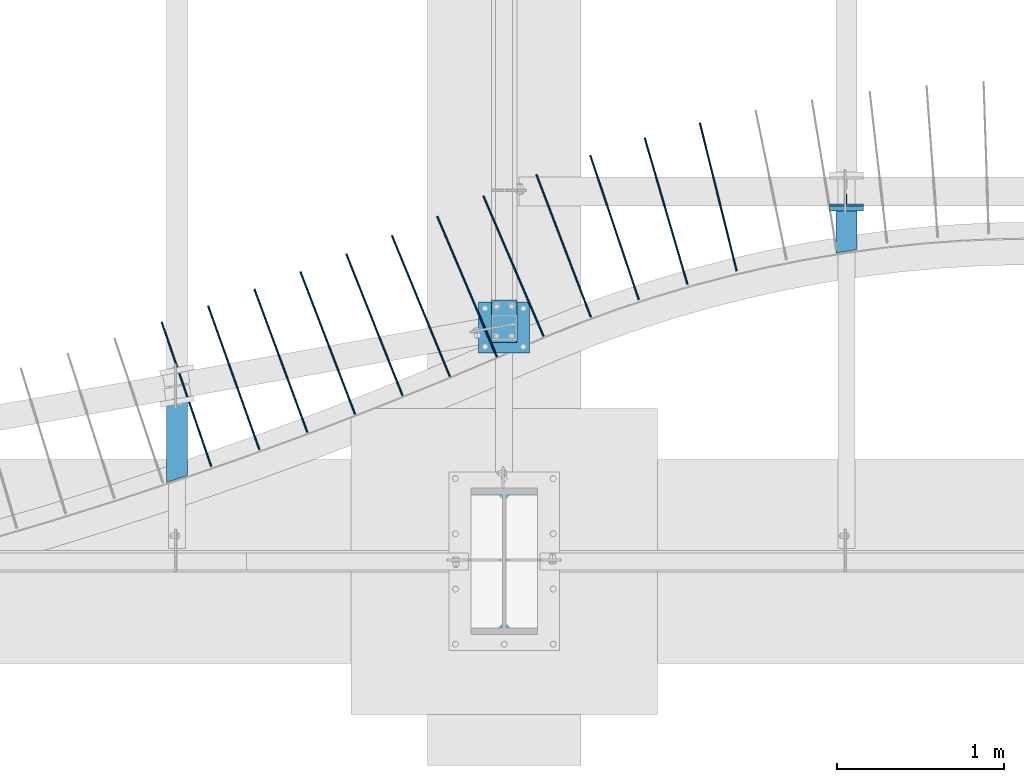
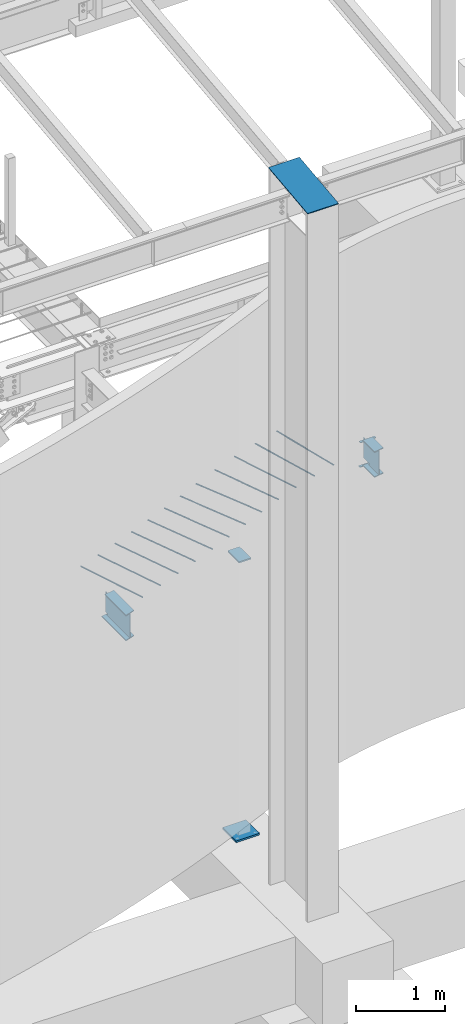
# One storey, part 808 of 1179: 19 beams, 16 elements without a shape of their own.
"""IFC2X3 building model written with IfcOpenShell, lengths in millimetres."""

from ifc_helpers import new_model, si_unit, frame, origin_with_axes, place, context, subcontext, project, spatial, faceted_brep, material, type_object, element, aggregate, save


model = new_model("IFC2X3")

# Units and contexts
model_context = context("Model", 3, precision=1e-05, world=origin_with_axes())
body_context = subcontext(model_context, "Body", "Model", "MODEL_VIEW")
ifc_project = project(units=[si_unit("LENGTHUNIT", "METRE", prefix="MILLI"), si_unit("AREAUNIT", "SQUARE_METRE"), si_unit("VOLUMEUNIT", "CUBIC_METRE"), si_unit("MASSUNIT", "GRAM", prefix="KILO"), si_unit("TIMEUNIT", "SECOND"), si_unit("PLANEANGLEUNIT", "RADIAN"), si_unit("SOLIDANGLEUNIT", "STERADIAN"), si_unit("THERMODYNAMICTEMPERATUREUNIT", "DEGREE_CELSIUS"), si_unit("LUMINOUSINTENSITYUNIT", "LUMEN")], contexts=[model_context])

# Site, building, storey
site_placement = place(None, origin_with_axes())
site = spatial("IfcSite", under=ifc_project, at=site_placement, CompositionType="ELEMENT")
building_placement = place(site_placement, origin_with_axes())
building = spatial("IfcBuilding", under=site, at=building_placement, Name="Undefined", CompositionType="ELEMENT")
storey_placement = place(building_placement, origin_with_axes())
storey = spatial("IfcBuildingStorey", under=building, at=storey_placement, Name="Undefined", CompositionType="ELEMENT", Elevation=0.0)

# Assembly, beams
assembly_1_placement = place(storey_placement, origin_with_axes())
assembly_1 = element("IfcElementAssembly", 1, at=assembly_1_placement, inside=storey, Name="BEAM", AssemblyPlace="NOTDEFINED", PredefinedType="RIGID_FRAME")
ifc_material_1 = material(Name="STEEL/A36")
beam_type_1 = type_object("IfcBeamType", PredefinedType="NOTDEFINED")
beam_1_placement = place(assembly_1_placement, frame((10325.1, 2530.47499999652, 3831.8280002594), z_axis=(-1.0, 0.0, 0.0), x_axis=(0.0, 1.0, 0.0)))
beam_1 = element("IfcBeam", 2, at=beam_1_placement, type_object=beam_type_1, material=ifc_material_1, Name="PLATE", context=body_context, shape_type="Brep", body=[
    faceted_brep([(0.0, 4.76250000000073, -101.6), (0.0, 4.76250000000073, 101.6), (31.75, 4.76249999999982, 101.6), (31.75, 4.76249999999982, -101.6), (0.0, -4.76250000000073, 101.6), (31.75, -4.76249999999982, 101.6), (0.0, -4.76250000000073, -101.6), (31.75, -4.76249999999982, -101.6)], [[[0, 1, 2, 3]], [[1, 4, 5, 2]], [[4, 6, 7, 5]], [[6, 0, 3, 7]], [[5, 7, 3, 2]], [[6, 4, 1, 0]]]),
])
beam_2_placement = place(assembly_1_placement, frame((10325.1, 2541.58712563067, 3490.9125), z_axis=(-1.0, 0.0, 0.0), x_axis=(0.0, 1.0, 0.0)))
beam_2 = element("IfcBeam", 3, at=beam_2_placement, type_object=beam_type_1, material=ifc_material_1, Name="PLATE", context=body_context, shape_type="Brep", body=[
    faceted_brep([(0.0, 4.76250000000073, -101.6), (0.0, 4.76250000000073, 101.6), (31.75, 4.76249999999982, 101.6), (31.75, 4.76249999999982, -101.6), (0.0, -4.76250000000073, 101.6), (31.75, -4.76249999999982, 101.6), (0.0, -4.76250000000073, -101.6), (31.75, -4.76249999999982, -101.6)], [[[0, 1, 2, 3]], [[1, 4, 5, 2]], [[4, 6, 7, 5]], [[6, 0, 3, 7]], [[5, 7, 3, 2]], [[6, 4, 1, 0]]]),
])

# Assembly, beam
assembly_2_placement = place(storey_placement, origin_with_axes())
assembly_2 = element("IfcElementAssembly", 4, at=assembly_2_placement, inside=storey, Name="COLUMN", AssemblyPlace="NOTDEFINED", PredefinedType="RIGID_FRAME")
beam_type_2 = type_object("IfcBeamType", PredefinedType="NOTDEFINED")
beam_3_placement = place(assembly_2_placement, frame((8280.4, 876.834752967023, 9341.1779874812), z_axis=(1.0, 0.0, 0.0), x_axis=(0.0, -0.993676146336441, -0.112284087038017)))
beam_3 = element("IfcBeam", 5, at=beam_3_placement, type_object=beam_type_2, material=ifc_material_1, Name="PLATE", context=body_context, shape_type="Brep", body=[
    faceted_brep([(1.07631237348505, 4.76249999999709, -200.025), (1.07631237348505, 4.76249999999709, 200.025), (882.953172586766, 4.762499999586, 200.025), (882.953172586766, 4.762499999586, -200.025), (2.52225618169177e-09, -4.76249999999709, 200.025), (881.876860215802, -4.76250000041, 200.025), (2.52225618169177e-09, -4.76249999999709, -200.025), (881.876860215802, -4.76250000041, -200.025)], [[[0, 1, 2, 3]], [[1, 4, 5, 2]], [[4, 6, 7, 5]], [[6, 0, 3, 7]], [[5, 7, 3, 2]], [[6, 4, 1, 0]]]),
])
aggregate(assembly_2, [beam_3])

assembly_3_placement = place(storey_placement, origin_with_axes())
assembly_3 = element("IfcElementAssembly", 6, at=assembly_3_placement, inside=storey, Name="#4 DOWEL", AssemblyPlace="NOTDEFINED", PredefinedType="NOTDEFINED")
ifc_material_2 = material(Name="REBAR/A615-40")
beam_type_3 = type_object("IfcBeamType", Name="#4 DOWEL", PredefinedType="NOTDEFINED")
beam_4_placement = place(assembly_3_placement, frame((9669.62575980426, 2171.91771749365, 3943.35000610352), z_axis=(-0.970440166759231, -0.241341837940122, 0.0), x_axis=(-0.241341837940122, 0.970440166759231, 0.0)))
beam_4 = element("IfcBeam", 7, at=beam_4_placement, type_object=beam_type_3, material=ifc_material_2, Name="#4 DOWEL", ObjectType="#4 DOWEL", context=body_context, shape_type="Brep", body=[
    faceted_brep([(0.0, -6.34999999999854, 0.0), (0.0, -4.49012806053361, -4.49012806053452), (914.399999999994, -4.49012806053452, -4.49012806042992), (914.399999999994, -6.34999999999991, 1.0550138540566e-10), (0.0, 0.0, -6.34999999999991), (914.399999999994, 0.0, -6.34999999989668), (0.0, 4.49012806053361, -4.49012806053452), (914.399999999994, 4.49012806053452, -4.49012806042992), (0.0, 6.34999999999854, 0.0), (914.399999999994, 6.34999999999991, 1.0550138540566e-10), (0.0, 4.49012806053361, 4.49012806053452), (914.399999999995, 4.49012806053452, 4.49012806064184), (0.0, 0.0, 6.34999999999991), (914.399999999995, 0.0, 6.35000000010768), (0.0, -4.49012806053361, 4.49012806053452), (914.399999999995, -4.49012806053452, 4.49012806064184)], [[[0, 1, 2, 3]], [[1, 4, 5, 2]], [[4, 6, 7, 5]], [[6, 8, 9, 7]], [[8, 10, 11, 9]], [[10, 12, 13, 11]], [[12, 14, 15, 13]], [[14, 0, 3, 15]], [[5, 7, 9, 11, 13, 15, 3, 2]], [[14, 12, 10, 8, 6, 4, 1, 0]]]),
])
aggregate(assembly_3, [beam_4])

assembly_4_placement = place(storey_placement, origin_with_axes())
assembly_4 = element("IfcElementAssembly", 8, at=assembly_4_placement, inside=storey, Name="#4 DOWEL", AssemblyPlace="NOTDEFINED", PredefinedType="NOTDEFINED")
beam_5_placement = place(assembly_4_placement, frame((9375.52245592105, 2092.09142991798, 3943.35000610352), z_axis=(-0.959918661545665, -0.280278724159325, 0.0), x_axis=(-0.280278724159325, 0.959918661545665, 0.0)))
beam_5 = element("IfcBeam", 9, at=beam_5_placement, type_object=beam_type_3, material=ifc_material_2, Name="#4 DOWEL", ObjectType="#4 DOWEL", context=body_context, shape_type="Brep", body=[
    faceted_brep([(0.0, -6.34999999999854, 0.0), (0.0, -4.49012806053361, -4.49012806053452), (914.399999999994, -4.49012806053452, -4.49012806042992), (914.399999999994, -6.34999999999991, 1.0550138540566e-10), (0.0, 0.0, -6.34999999999991), (914.399999999994, 0.0, -6.34999999989668), (0.0, 4.49012806053361, -4.49012806053452), (914.399999999994, 4.49012806053452, -4.49012806042992), (0.0, 6.34999999999854, 0.0), (914.399999999994, 6.34999999999991, 1.0550138540566e-10), (0.0, 4.49012806053361, 4.49012806053452), (914.399999999995, 4.49012806053452, 4.49012806064184), (0.0, 0.0, 6.34999999999991), (914.399999999995, 0.0, 6.35000000010768), (0.0, -4.49012806053361, 4.49012806053452), (914.399999999995, -4.49012806053452, 4.49012806064184)], [[[0, 1, 2, 3]], [[1, 4, 5, 2]], [[4, 6, 7, 5]], [[6, 8, 9, 7]], [[8, 10, 11, 9]], [[10, 12, 13, 11]], [[12, 14, 15, 13]], [[14, 0, 3, 15]], [[5, 7, 9, 11, 13, 15, 3, 2]], [[14, 12, 10, 8, 6, 4, 1, 0]]]),
])
aggregate(assembly_4, [beam_5])

assembly_5_placement = place(storey_placement, origin_with_axes())
assembly_5 = element("IfcElementAssembly", 10, at=assembly_5_placement, inside=storey, Name="#4 DOWEL", AssemblyPlace="NOTDEFINED", PredefinedType="NOTDEFINED")
beam_6_placement = place(assembly_5_placement, frame((9085.03763492726, 1999.7876022579, 3943.35000610352), z_axis=(-0.947835576717924, -0.318759657905137, 0.0), x_axis=(-0.318759657905137, 0.947835576717924, 0.0)))
beam_6 = element("IfcBeam", 11, at=beam_6_placement, type_object=beam_type_3, material=ifc_material_2, Name="#4 DOWEL", ObjectType="#4 DOWEL", context=body_context, shape_type="Brep", body=[
    faceted_brep([(0.0, -6.34999999999854, 0.0), (0.0, -4.49012806053361, -4.49012806053452), (914.399999999994, -4.49012806053452, -4.49012806042992), (914.399999999994, -6.34999999999991, 1.0550138540566e-10), (0.0, 0.0, -6.34999999999991), (914.399999999994, 0.0, -6.34999999989668), (0.0, 4.49012806053361, -4.49012806053452), (914.399999999994, 4.49012806053452, -4.49012806042992), (0.0, 6.34999999999854, 0.0), (914.399999999994, 6.34999999999991, 1.0550138540566e-10), (0.0, 4.49012806053361, 4.49012806053452), (914.399999999995, 4.49012806053452, 4.49012806064184), (0.0, 0.0, 6.34999999999991), (914.399999999995, 0.0, 6.35000000010768), (0.0, -4.49012806053361, 4.49012806053452), (914.399999999995, -4.49012806053452, 4.49012806064184)], [[[0, 1, 2, 3]], [[1, 4, 5, 2]], [[4, 6, 7, 5]], [[6, 8, 9, 7]], [[8, 10, 11, 9]], [[10, 12, 13, 11]], [[12, 14, 15, 13]], [[14, 0, 3, 15]], [[5, 7, 9, 11, 13, 15, 3, 2]], [[14, 12, 10, 8, 6, 4, 1, 0]]]),
])
aggregate(assembly_5, [beam_6])

assembly_6_placement = place(storey_placement, origin_with_axes())
assembly_6 = element("IfcElementAssembly", 12, at=assembly_6_placement, inside=storey, Name="#4 DOWEL", AssemblyPlace="NOTDEFINED", PredefinedType="NOTDEFINED")
beam_7_placement = place(assembly_6_placement, frame((8798.30900210602, 1896.39141514167, 3943.35000610352), z_axis=(-0.934210569174614, -0.356722038066676, 0.0), x_axis=(-0.356722038066676, 0.934210569174614, 0.0)))
beam_7 = element("IfcBeam", 13, at=beam_7_placement, type_object=beam_type_3, material=ifc_material_2, Name="#4 DOWEL", ObjectType="#4 DOWEL", context=body_context, shape_type="Brep", body=[
    faceted_brep([(0.0, -6.34999999999854, 0.0), (0.0, -4.49012806053361, -4.49012806053452), (914.399999999994, -4.49012806053452, -4.49012806042992), (914.399999999994, -6.34999999999991, 1.0550138540566e-10), (0.0, 0.0, -6.34999999999991), (914.399999999994, 0.0, -6.34999999989668), (0.0, 4.49012806053361, -4.49012806053452), (914.399999999994, 4.49012806053452, -4.49012806042992), (0.0, 6.34999999999854, 0.0), (914.399999999994, 6.34999999999991, 1.0550138540566e-10), (0.0, 4.49012806053361, 4.49012806053452), (914.399999999995, 4.49012806053452, 4.49012806064184), (0.0, 0.0, 6.34999999999991), (914.399999999995, 0.0, 6.35000000010768), (0.0, -4.49012806053361, 4.49012806053452), (914.399999999995, -4.49012806053452, 4.49012806064184)], [[[0, 1, 2, 3]], [[1, 4, 5, 2]], [[4, 6, 7, 5]], [[6, 8, 9, 7]], [[8, 10, 11, 9]], [[10, 12, 13, 11]], [[12, 14, 15, 13]], [[14, 0, 3, 15]], [[5, 7, 9, 11, 13, 15, 3, 2]], [[14, 12, 10, 8, 6, 4, 1, 0]]]),
])
aggregate(assembly_6, [beam_7])

assembly_7_placement = place(storey_placement, origin_with_axes())
assembly_7 = element("IfcElementAssembly", 14, at=assembly_7_placement, inside=storey, Name="#4 DOWEL", AssemblyPlace="NOTDEFINED", PredefinedType="NOTDEFINED")
beam_8_placement = place(assembly_7_placement, frame((8515.76147625042, 1782.02824406485, 3943.35000610352), z_axis=(-0.919065803626469, -0.394104108839826, 0.0), x_axis=(-0.394104108839826, 0.919065803626469, 0.0)))
beam_8 = element("IfcBeam", 15, at=beam_8_placement, type_object=beam_type_3, material=ifc_material_2, Name="#4 DOWEL", ObjectType="#4 DOWEL", context=body_context, shape_type="Brep", body=[
    faceted_brep([(0.0, -6.34999999999854, 0.0), (0.0, -4.49012806053361, -4.49012806053452), (914.399999999994, -4.49012806053452, -4.49012806042992), (914.399999999994, -6.34999999999991, 1.0550138540566e-10), (0.0, 0.0, -6.34999999999991), (914.399999999994, 0.0, -6.34999999989668), (0.0, 4.49012806053361, -4.49012806053452), (914.399999999994, 4.49012806053452, -4.49012806042992), (0.0, 6.34999999999854, 0.0), (914.399999999994, 6.34999999999991, 1.0550138540566e-10), (0.0, 4.49012806053361, 4.49012806053452), (914.399999999995, 4.49012806053452, 4.49012806064184), (0.0, 0.0, 6.34999999999991), (914.399999999995, 0.0, 6.35000000010768), (0.0, -4.49012806053361, 4.49012806053452), (914.399999999995, -4.49012806053452, 4.49012806064184)], [[[0, 1, 2, 3]], [[1, 4, 5, 2]], [[4, 6, 7, 5]], [[6, 8, 9, 7]], [[8, 10, 11, 9]], [[10, 12, 13, 11]], [[12, 14, 15, 13]], [[14, 0, 3, 15]], [[5, 7, 9, 11, 13, 15, 3, 2]], [[14, 12, 10, 8, 6, 4, 1, 0]]]),
])
aggregate(assembly_7, [beam_8])

assembly_8_placement = place(storey_placement, origin_with_axes())
assembly_8 = element("IfcElementAssembly", 16, at=assembly_8_placement, inside=storey, Name="#4 DOWEL", AssemblyPlace="NOTDEFINED", PredefinedType="NOTDEFINED")
beam_9_placement = place(assembly_8_placement, frame((8237.11431819635, 1658.67674950508, 3943.35000610352), z_axis=(-0.920449788057154, -0.39086082902427, 0.0), x_axis=(-0.39086082902427, 0.920449788057154, 0.0)))
beam_9 = element("IfcBeam", 17, at=beam_9_placement, type_object=beam_type_3, material=ifc_material_2, Name="#4 DOWEL", ObjectType="#4 DOWEL", context=body_context, shape_type="Brep", body=[
    faceted_brep([(0.0, -6.34999999999854, 0.0), (0.0, -4.49012806053361, -4.49012806053452), (914.399999999994, -4.49012806053452, -4.49012806042992), (914.399999999994, -6.34999999999991, 1.0550138540566e-10), (0.0, 0.0, -6.34999999999991), (914.399999999994, 0.0, -6.34999999989668), (0.0, 4.49012806053361, -4.49012806053452), (914.399999999994, 4.49012806053452, -4.49012806042992), (0.0, 6.34999999999854, 0.0), (914.399999999994, 6.34999999999991, 1.0550138540566e-10), (0.0, 4.49012806053361, 4.49012806053452), (914.399999999995, 4.49012806053452, 4.49012806064184), (0.0, 0.0, 6.34999999999991), (914.399999999995, 0.0, 6.35000000010768), (0.0, -4.49012806053361, 4.49012806053452), (914.399999999995, -4.49012806053452, 4.49012806064184)], [[[0, 1, 2, 3]], [[1, 4, 5, 2]], [[4, 6, 7, 5]], [[6, 8, 9, 7]], [[8, 10, 11, 9]], [[10, 12, 13, 11]], [[12, 14, 15, 13]], [[14, 0, 3, 15]], [[5, 7, 9, 11, 13, 15, 3, 2]], [[14, 12, 10, 8, 6, 4, 1, 0]]]),
])
aggregate(assembly_8, [beam_9])

assembly_9_placement = place(storey_placement, origin_with_axes())
assembly_9 = element("IfcElementAssembly", 18, at=assembly_9_placement, inside=storey, Name="#4 DOWEL", AssemblyPlace="NOTDEFINED", PredefinedType="NOTDEFINED")
beam_10_placement = place(assembly_9_placement, frame((7955.90440144294, 1541.15521169166, 3943.35000610352), z_axis=(-0.925003051117784, -0.379959676048382, 0.0), x_axis=(-0.379959676048382, 0.925003051117784, 0.0)))
beam_10 = element("IfcBeam", 19, at=beam_10_placement, type_object=beam_type_3, material=ifc_material_2, Name="#4 DOWEL", ObjectType="#4 DOWEL", context=body_context, shape_type="Brep", body=[
    faceted_brep([(0.0, -6.34999999999854, 0.0), (0.0, -4.49012806053361, -4.49012806053452), (914.399999999994, -4.49012806053452, -4.49012806042992), (914.399999999994, -6.34999999999991, 1.0550138540566e-10), (0.0, 0.0, -6.34999999999991), (914.399999999994, 0.0, -6.34999999989668), (0.0, 4.49012806053361, -4.49012806053452), (914.399999999994, 4.49012806053452, -4.49012806042992), (0.0, 6.34999999999854, 0.0), (914.399999999994, 6.34999999999991, 1.0550138540566e-10), (0.0, 4.49012806053361, 4.49012806053452), (914.399999999995, 4.49012806053452, 4.49012806064184), (0.0, 0.0, 6.34999999999991), (914.399999999995, 0.0, 6.35000000010768), (0.0, -4.49012806053361, 4.49012806053452), (914.399999999995, -4.49012806053452, 4.49012806064184)], [[[0, 1, 2, 3]], [[1, 4, 5, 2]], [[4, 6, 7, 5]], [[6, 8, 9, 7]], [[8, 10, 11, 9]], [[10, 12, 13, 11]], [[12, 14, 15, 13]], [[14, 0, 3, 15]], [[5, 7, 9, 11, 13, 15, 3, 2]], [[14, 12, 10, 8, 6, 4, 1, 0]]]),
])
aggregate(assembly_9, [beam_10])

assembly_10_placement = place(storey_placement, origin_with_axes())
assembly_10 = element("IfcElementAssembly", 20, at=assembly_10_placement, inside=storey, Name="#4 DOWEL", AssemblyPlace="NOTDEFINED", PredefinedType="NOTDEFINED")
beam_11_placement = place(assembly_10_placement, frame((7673.11932932328, 1427.44317889336, 3943.35000610352), z_axis=(-0.929427213662624, -0.369005493866054, 0.0), x_axis=(-0.369005493866054, 0.929427213662624, 0.0)))
beam_11 = element("IfcBeam", 21, at=beam_11_placement, type_object=beam_type_3, material=ifc_material_2, Name="#4 DOWEL", ObjectType="#4 DOWEL", context=body_context, shape_type="Brep", body=[
    faceted_brep([(0.0, -6.34999999999854, 0.0), (0.0, -4.49012806053361, -4.49012806053452), (914.399999999994, -4.49012806053452, -4.49012806042992), (914.399999999994, -6.34999999999991, 1.0550138540566e-10), (0.0, 0.0, -6.34999999999991), (914.399999999994, 0.0, -6.34999999989668), (0.0, 4.49012806053361, -4.49012806053452), (914.399999999994, 4.49012806053452, -4.49012806042992), (0.0, 6.34999999999854, 0.0), (914.399999999994, 6.34999999999991, 1.0550138540566e-10), (0.0, 4.49012806053361, 4.49012806053452), (914.399999999995, 4.49012806053452, 4.49012806064184), (0.0, 0.0, 6.34999999999991), (914.399999999995, 0.0, 6.35000000010768), (0.0, -4.49012806053361, 4.49012806053452), (914.399999999995, -4.49012806053452, 4.49012806064184)], [[[0, 1, 2, 3]], [[1, 4, 5, 2]], [[4, 6, 7, 5]], [[6, 8, 9, 7]], [[8, 10, 11, 9]], [[10, 12, 13, 11]], [[12, 14, 15, 13]], [[14, 0, 3, 15]], [[5, 7, 9, 11, 13, 15, 3, 2]], [[14, 12, 10, 8, 6, 4, 1, 0]]]),
])
aggregate(assembly_10, [beam_11])

assembly_11_placement = place(storey_placement, origin_with_axes())
assembly_11 = element("IfcElementAssembly", 22, at=assembly_11_placement, inside=storey, Name="#4 DOWEL", AssemblyPlace="NOTDEFINED", PredefinedType="NOTDEFINED")
beam_12_placement = place(assembly_11_placement, frame((7389.19135033417, 1316.63266355857, 3943.35000610352), z_axis=(-0.933721658791898, -0.357999809920211, 0.0), x_axis=(-0.357999809920211, 0.933721658791898, 0.0)))
beam_12 = element("IfcBeam", 23, at=beam_12_placement, type_object=beam_type_3, material=ifc_material_2, Name="#4 DOWEL", ObjectType="#4 DOWEL", context=body_context, shape_type="Brep", body=[
    faceted_brep([(0.0, -6.34999999999854, 0.0), (0.0, -4.49012806053361, -4.49012806053452), (914.399999999994, -4.49012806053452, -4.49012806042992), (914.399999999994, -6.34999999999991, 1.0550138540566e-10), (0.0, 0.0, -6.34999999999991), (914.399999999994, 0.0, -6.34999999989668), (0.0, 4.49012806053361, -4.49012806053452), (914.399999999994, 4.49012806053452, -4.49012806042992), (0.0, 6.34999999999854, 0.0), (914.399999999994, 6.34999999999991, 1.0550138540566e-10), (0.0, 4.49012806053361, 4.49012806053452), (914.399999999995, 4.49012806053452, 4.49012806064184), (0.0, 0.0, 6.34999999999991), (914.399999999995, 0.0, 6.35000000010768), (0.0, -4.49012806053361, 4.49012806053452), (914.399999999995, -4.49012806053452, 4.49012806064184)], [[[0, 1, 2, 3]], [[1, 4, 5, 2]], [[4, 6, 7, 5]], [[6, 8, 9, 7]], [[8, 10, 11, 9]], [[10, 12, 13, 11]], [[12, 14, 15, 13]], [[14, 0, 3, 15]], [[5, 7, 9, 11, 13, 15, 3, 2]], [[14, 12, 10, 8, 6, 4, 1, 0]]]),
])
aggregate(assembly_11, [beam_12])

assembly_12_placement = place(storey_placement, origin_with_axes())
assembly_12 = element("IfcElementAssembly", 24, at=assembly_12_placement, inside=storey, Name="#4 DOWEL", AssemblyPlace="NOTDEFINED", PredefinedType="NOTDEFINED")
beam_13_placement = place(assembly_12_placement, frame((7104.13813463885, 1208.73055740952, 3943.35000610352), z_axis=(-0.937885786855283, -0.346944160946466, 0.0), x_axis=(-0.346944160946466, 0.937885786855283, 0.0)))
beam_13 = element("IfcBeam", 25, at=beam_13_placement, type_object=beam_type_3, material=ifc_material_2, Name="#4 DOWEL", ObjectType="#4 DOWEL", context=body_context, shape_type="Brep", body=[
    faceted_brep([(0.0, -6.34999999999854, 0.0), (0.0, -4.49012806053361, -4.49012806053452), (914.399999999994, -4.49012806053452, -4.49012806042992), (914.399999999994, -6.34999999999991, 1.0550138540566e-10), (0.0, 0.0, -6.34999999999991), (914.399999999994, 0.0, -6.34999999989668), (0.0, 4.49012806053361, -4.49012806053452), (914.399999999994, 4.49012806053452, -4.49012806042992), (0.0, 6.34999999999854, 0.0), (914.399999999994, 6.34999999999991, 1.0550138540566e-10), (0.0, 4.49012806053361, 4.49012806053452), (914.399999999995, 4.49012806053452, 4.49012806064184), (0.0, 0.0, 6.34999999999991), (914.399999999995, 0.0, 6.35000000010768), (0.0, -4.49012806053361, 4.49012806053452), (914.399999999995, -4.49012806053452, 4.49012806064184)], [[[0, 1, 2, 3]], [[1, 4, 5, 2]], [[4, 6, 7, 5]], [[6, 8, 9, 7]], [[8, 10, 11, 9]], [[10, 12, 13, 11]], [[12, 14, 15, 13]], [[14, 0, 3, 15]], [[5, 7, 9, 11, 13, 15, 3, 2]], [[14, 12, 10, 8, 6, 4, 1, 0]]]),
])
aggregate(assembly_12, [beam_13])

assembly_13_placement = place(storey_placement, origin_with_axes())
assembly_13 = element("IfcElementAssembly", 26, at=assembly_13_placement, inside=storey, Name="#4 DOWEL", AssemblyPlace="NOTDEFINED", PredefinedType="NOTDEFINED")
beam_14_placement = place(assembly_13_placement, frame((6817.52247727597, 1105.08892642683, 3943.35000610352), z_axis=(-0.941919016699785, -0.335840089892958, 0.0), x_axis=(-0.335840089892958, 0.941919016699785, 0.0)))
beam_14 = element("IfcBeam", 27, at=beam_14_placement, type_object=beam_type_3, material=ifc_material_2, Name="#4 DOWEL", ObjectType="#4 DOWEL", context=body_context, shape_type="Brep", body=[
    faceted_brep([(0.0, -6.34999999999854, 0.0), (0.0, -4.49012806053361, -4.49012806053452), (914.399999999994, -4.49012806053452, -4.49012806042992), (914.399999999994, -6.34999999999991, 1.0550138540566e-10), (0.0, 0.0, -6.34999999999991), (914.399999999994, 0.0, -6.34999999989668), (0.0, 4.49012806053361, -4.49012806053452), (914.399999999994, 4.49012806053452, -4.49012806042992), (0.0, 6.34999999999854, 0.0), (914.399999999994, 6.34999999999991, 1.0550138540566e-10), (0.0, 4.49012806053361, 4.49012806053452), (914.399999999995, 4.49012806053452, 4.49012806064184), (0.0, 0.0, 6.34999999999991), (914.399999999995, 0.0, 6.35000000010768), (0.0, -4.49012806053361, 4.49012806053452), (914.399999999995, -4.49012806053452, 4.49012806064184)], [[[0, 1, 2, 3]], [[1, 4, 5, 2]], [[4, 6, 7, 5]], [[6, 8, 9, 7]], [[8, 10, 11, 9]], [[10, 12, 13, 11]], [[12, 14, 15, 13]], [[14, 0, 3, 15]], [[5, 7, 9, 11, 13, 15, 3, 2]], [[14, 12, 10, 8, 6, 4, 1, 0]]]),
])
aggregate(assembly_13, [beam_14])

assembly_14_placement = place(storey_placement, origin_with_axes())
assembly_14 = element("IfcElementAssembly", 28, at=assembly_14_placement, inside=storey, Name="#4 DOWEL", AssemblyPlace="NOTDEFINED", PredefinedType="NOTDEFINED")
beam_15_placement = place(assembly_14_placement, frame((6529.7159513591, 1004.78728655242, 3943.35000610352), z_axis=(-0.94582078522813, -0.324689147078315, 0.0), x_axis=(-0.324689147078315, 0.94582078522813, 0.0)))
beam_15 = element("IfcBeam", 29, at=beam_15_placement, type_object=beam_type_3, material=ifc_material_2, Name="#4 DOWEL", ObjectType="#4 DOWEL", context=body_context, shape_type="Brep", body=[
    faceted_brep([(0.0, -6.34999999999854, 0.0), (0.0, -4.49012806053361, -4.49012806053452), (914.399999999994, -4.49012806053452, -4.49012806042992), (914.399999999994, -6.34999999999991, 1.0550138540566e-10), (0.0, 0.0, -6.34999999999991), (914.399999999994, 0.0, -6.34999999989668), (0.0, 4.49012806053361, -4.49012806053452), (914.399999999994, 4.49012806053452, -4.49012806042992), (0.0, 6.34999999999854, 0.0), (914.399999999994, 6.34999999999991, 1.0550138540566e-10), (0.0, 4.49012806053361, 4.49012806053452), (914.399999999995, 4.49012806053452, 4.49012806064184), (0.0, 0.0, 6.34999999999991), (914.399999999995, 0.0, 6.35000000010768), (0.0, -4.49012806053361, 4.49012806053452), (914.399999999995, -4.49012806053452, 4.49012806064184)], [[[0, 1, 2, 3]], [[1, 4, 5, 2]], [[4, 6, 7, 5]], [[6, 8, 9, 7]], [[8, 10, 11, 9]], [[10, 12, 13, 11]], [[12, 14, 15, 13]], [[14, 0, 3, 15]], [[5, 7, 9, 11, 13, 15, 3, 2]], [[14, 12, 10, 8, 6, 4, 1, 0]]]),
])
aggregate(assembly_14, [beam_15])

# Assembly, beams
assembly_15_placement = place(storey_placement, origin_with_axes())
assembly_15 = element("IfcElementAssembly", 30, at=assembly_15_placement, inside=storey, Name="COLUMN", AssemblyPlace="NOTDEFINED", PredefinedType="RIGID_FRAME")
beam_type_4 = type_object("IfcBeamType", PredefinedType="NOTDEFINED")
beam_16_placement = place(assembly_15_placement, frame((8280.4000000008, 1746.1649461189, 3381.3750000127), z_axis=(1.0, 0.0, 0.0), x_axis=(0.0, 1.0, 0.0)))
beam_16 = element("IfcBeam", 31, at=beam_16_placement, type_object=beam_type_4, material=ifc_material_1, Name="PLATE", context=body_context, shape_type="Brep", body=[
    faceted_brep([(0.0, 9.52500000000009, -76.2000000000007), (0.0, 9.52500000000009, 76.2000000000007), (254.0, 9.52500000000009, 76.2000000000007), (254.0, 9.52500000000009, -76.2000000000007), (0.0, -9.52500000000009, 76.2000000000007), (254.0, -9.52500000000009, 76.2000000000007), (0.0, -9.52500000000009, -76.2000000000007), (254.0, -9.52500000000009, -76.2000000000007)], [[[0, 1, 2, 3]], [[1, 4, 5, 2]], [[4, 6, 7, 5]], [[6, 0, 3, 7]], [[5, 7, 3, 2]], [[6, 4, 1, 0]]]),
])
ifc_material_3 = material(Name="STEEL/A572-GR.50")
beam_type_5 = type_object("IfcBeamType", PredefinedType="NOTDEFINED")
beam_17_placement = place(assembly_15_placement, frame((8128.00000000001, 1835.06494239091, -368.299999999999), z_axis=(0.0, 1.0, 0.0), x_axis=(1.0, 0.0, 0.0)))
beam_17 = element("IfcBeam", 32, at=beam_17_placement, type_object=beam_type_5, material=ifc_material_3, context=body_context, shape_type="Brep", body=[
    faceted_brep([(-7.27595761418343e-12, 12.7, -152.400000000011), (7.27595761418343e-12, 12.7, 152.400000000011), (304.800000000494, 12.7, 152.400000000071), (304.800000000479, 12.7, -152.39999999995), (7.27595761418343e-12, -12.7, 152.400000000011), (304.800000000494, -12.7, 152.400000000071), (-7.27595761418343e-12, -12.7, -152.400000000011), (304.800000000479, -12.7, -152.39999999995)], [[[0, 1, 2, 3]], [[1, 4, 5, 2]], [[4, 6, 7, 5]], [[6, 0, 3, 7]], [[5, 7, 3, 2]], [[6, 4, 1, 0]]]),
])
aggregate(assembly_15, [beam_16, beam_17])

# Assembly, beam
assembly_16_placement = place(storey_placement, origin_with_axes())
assembly_16 = element("IfcElementAssembly", 33, at=assembly_16_placement, inside=storey, Name="BEAM", AssemblyPlace="NOTDEFINED", PredefinedType="RIGID_FRAME")
ifc_material_4 = material(Name="STEEL/A992")
beam_type_6 = type_object("IfcBeamType", Name="W14X26", PredefinedType="NOTDEFINED")
beam_18_placement = place(assembly_16_placement, frame((6324.6, 930.05599110407, 3671.8875), z_axis=(0.0, 0.0, 1.0), x_axis=(0.0, 1.0, 0.0)))
beam_18 = element("IfcBeam", 34, at=beam_18_placement, type_object=beam_type_6, material=ifc_material_4, Name="BEAM", ObjectType="W14X26", context=body_context, shape_type="Brep", body=[
    faceted_brep([(539.738567107714, -3.17500000020664, 139.7), (539.738567107714, -3.17500000020664, -139.7), (538.608376982559, 3.17499999979373, -139.7), (538.608376982559, 3.17499999979373, 139.7), (-21.2027358389676, 63.5000000000073, 165.1), (-21.2027358389676, 63.5000000000073, 176.2125), (451.554249373419, 63.4999999998272, 176.2125), (458.070689004176, 63.4999999998245, 165.1), (-0.66431910017377, 3.17499999999927, 165.1), (468.807495193152, 3.17499999982101, 165.1), (-21.2027358389676, 63.5000000000073, -165.1), (-0.66431910017377, 3.17499999999927, -165.1), (535.317210669876, 3.17499999979464, -165.1), (524.580404480899, 63.4999999997999, -165.1), (501.860316592178, -3.17500000019209, -141.10912014425), (500.730126467018, 3.17499999980828, -141.10912014425), (505.794271961492, 3.17499999980646, -139.7), (506.924462086652, -3.1750000001939, -139.7), (498.294541641635, -3.17500000019027, -144.919552564306), (497.164351516475, 3.1749999998101, -144.919552564306), (497.282172513532, -3.17500000019027, -150.003873155929), (496.151982388372, 3.1749999998101, -150.003873155929), (499.122747221299, -3.17500000019118, -154.857742002601), (497.992557096139, 3.17499999980919, -154.857742002601), (503.271679727858, -3.17500000019299, -158.045004848507), (502.141489602698, 3.17499999980828, -158.045004848507), (519.857335202483, -3.17500000019936, -164.703000259399), (518.727145077323, 3.17499999980191, -164.703000259399), (536.214611103425, -3.17500000020573, -164.703000259399), (535.08442097827, 3.17499999979555, -164.703000259399), (22.0360362427036, -63.5000000000091, -176.2125), (-21.2027358389676, 63.5000000000073, -176.2125), (531.096467801379, 63.4999999997963, -176.2125), (553.700270304487, -63.5000000002119, -176.2125), (22.0360362427036, -63.5000000000091, -165.1), (547.184206984008, -63.5000000002092, -165.1), (1.49761950390973, -3.17500000000109, -165.1), (536.447400795031, -3.17500000020482, -165.1), (1.49761950390973, -3.17500000000109, 165.1), (22.0360362427036, -63.5000000000091, 165.1), (22.0360362427036, -63.5000000000091, 176.2125), (469.937685318307, -3.17500000017935, 165.1), (480.674491507284, -63.5000000001846, 165.1), (474.158051876527, -63.5000000001819, 176.2125), (470.17048845379, -3.17500000018026, 164.703000259399), (469.040298328635, 3.17499999982101, 164.703000259399), (447.597103255478, -3.17500000017117, 164.703000259399), (446.466913130318, 3.1749999998292, 164.703000259399), (431.011447780853, -3.1750000001648, 158.045004848507), (429.881257655693, 3.17499999983556, 158.045004848507), (426.862515274293, -3.17500000016389, 154.857742002601), (425.732325149133, 3.17499999983738, 154.857742002601), (425.021940566526, -3.17500000016298, 150.003873155928), (423.891750441366, 3.17499999983738, 150.003873155928), (426.034309694629, -3.17500000016298, 144.919552564306), (424.904119569469, 3.17499999983738, 144.919552564306), (429.600084645172, -3.1750000001648, 141.10912014425), (428.469894520012, 3.17499999983556, 141.10912014425), (434.664230139647, -3.17500000016571, 139.7), (433.534040014487, 3.17499999983374, 139.7)], [[[0, 1, 2, 3]], [[4, 5, 6, 7]], [[8, 4, 7, 9]], [[10, 11, 12, 13]], [[14, 15, 16, 17]], [[18, 19, 15, 14]], [[20, 21, 19, 18]], [[22, 23, 21, 20]], [[24, 25, 23, 22]], [[26, 27, 25, 24]], [[27, 26, 28, 29]], [[30, 31, 32, 33]], [[34, 30, 33, 35]], [[36, 34, 35, 37]], [[33, 32, 13, 12, 29, 28, 37, 35]], [[31, 10, 13, 32]], [[30, 34, 36, 38, 39, 40, 5, 4, 8, 11, 10, 31]], [[39, 38, 41, 42]], [[40, 39, 42, 43]], [[5, 40, 43, 6]], [[42, 41, 44, 45, 9, 7, 6, 43]], [[46, 47, 45, 44]], [[48, 49, 47, 46]], [[50, 51, 49, 48]], [[52, 53, 51, 50]], [[54, 55, 53, 52]], [[56, 57, 55, 54]], [[58, 59, 57, 56]], [[59, 58, 0, 3]], [[16, 15, 19, 21, 23, 25, 27, 29, 12, 11, 8, 9, 45, 47, 49, 51, 53, 55, 57, 59, 3, 2]], [[17, 16, 2, 1]], [[58, 56, 54, 52, 50, 48, 46, 44, 41, 38, 36, 37, 28, 26, 24, 22, 20, 18, 14, 17, 1, 0]]]),
])
aggregate(assembly_16, [beam_18])

# Beam
beam_19_placement = place(assembly_1_placement, frame((10325.1, 2290.8156196875, 3671.8875), z_axis=(0.0, 0.0, 1.0), x_axis=(0.0, 1.0, 0.0)))
beam_19 = element("IfcBeam", 35, at=beam_19_placement, type_object=beam_type_6, material=ifc_material_4, Name="BEAM", ObjectType="W14X26", context=body_context, shape_type="Brep", body=[
    faceted_brep([(-9.88796703645903, 63.5, -165.1), (-0.494398324291069, 3.17499999999927, -165.1), (255.468757636044, 3.17499999999927, -165.1), (255.468757636044, 63.5, -165.1), (223.330345782112, -3.17499999999927, 158.045004848507), (223.330345782112, 3.17499999999927, 158.045004848507), (239.659383364256, 3.17499999999927, 164.703000259399), (239.659383364256, -3.17499999999927, 164.703000259399), (219.24560671774, -3.17499999999927, 154.857742002601), (219.24560671774, 3.17499999999927, 154.857742002601), (217.433509895769, -3.17499999999927, 150.003873155928), (217.433509895769, 3.17499999999927, 150.003873155928), (218.430215366053, -3.17499999999927, 144.919552564306), (218.430215366053, 3.17499999999927, 144.919552564306), (221.940819650941, -3.17499999999927, 141.10912014425), (221.940819650941, 3.17499999999927, 141.10912014425), (226.926611272336, -3.17499999999927, 139.7), (226.926611272336, 3.17499999999927, 139.7), (341.259380312498, -3.17499999999927, 139.7), (341.259380312498, 3.17499999999927, 139.7), (341.259380312498, -3.17499999999927, -139.7), (341.259380312498, 3.17499999999927, -139.7), (341.259380312498, 3.17499999999927, -92.4874999999997), (341.259380312498, 3.17499999999927, 138.1125), (220.052607366328, -3.17499999999927, -139.7), (220.052607366328, 3.17499999999927, -139.7), (215.066815744934, -3.17499999999927, -141.10912014425), (215.066815744934, 3.17499999999927, -141.10912014425), (211.556211460046, -3.17499999999927, -144.919552564306), (211.556211460046, 3.17499999999927, -144.919552564306), (210.559505989762, -3.17499999999927, -150.003873155929), (210.559505989762, 3.17499999999927, -150.003873155929), (212.371602811733, -3.17499999999927, -154.857742002601), (212.371602811733, 3.17499999999927, -154.857742002601), (216.456341876104, -3.17499999999927, -158.045004848507), (216.456341876104, 3.17499999999927, -158.045004848507), (232.785379458248, -3.17499999999927, -164.703000259399), (232.785379458248, 3.17499999999927, -164.703000259399), (255.239569612304, -3.17499999999927, -164.703000259399), (255.239569612304, 3.17499999999927, -164.703000259399), (9.88796709442067, -63.5, -176.2125), (-9.88796703645903, 63.5, -176.2125), (261.88400594317, 63.5, -176.2125), (261.88400594317, -63.5, -176.2125), (9.88796709442067, -63.5, -165.1), (255.468757636044, -63.5, -165.1), (0.494398382252712, -3.17499999999927, -165.1), (255.468757636044, -3.17499999999927, -165.1), (0.494398382252712, -3.17499999999927, 165.1), (9.88796709442067, -63.5, 165.1), (9.88796709442067, -63.5, 176.2125), (-9.88796703645903, 63.5, 176.2125), (-9.88796703645903, 63.5, 165.1), (-0.494398324291069, 3.17499999999927, 165.1), (255.468783123662, 63.5, 176.2125), (261.8843919055, 63.5, 165.1), (261.8843919055, 3.17499999999927, 165.1), (262.113592807384, 3.17499999999927, 164.703000259399), (262.113592807384, -3.17499999999927, 164.703000259399), (261.8843919055, -3.17499999999927, 165.1), (261.8843919055, -63.5, 165.1), (255.468783123662, -63.5, 176.2125)], [[[0, 1, 2, 3]], [[4, 5, 6, 7]], [[8, 9, 5, 4]], [[10, 11, 9, 8]], [[12, 13, 11, 10]], [[14, 15, 13, 12]], [[16, 17, 15, 14]], [[18, 19, 17, 16]], [[20, 21, 22, 23, 19, 18]], [[20, 24, 25, 21]], [[26, 27, 25, 24]], [[28, 29, 27, 26]], [[30, 31, 29, 28]], [[32, 33, 31, 30]], [[34, 35, 33, 32]], [[36, 37, 35, 34]], [[37, 36, 38, 39]], [[40, 41, 42, 43]], [[44, 40, 43, 45]], [[46, 44, 45, 47]], [[43, 42, 3, 2, 39, 38, 47, 45]], [[41, 0, 3, 42]], [[40, 44, 46, 48, 49, 50, 51, 52, 53, 1, 0, 41]], [[52, 51, 54, 55]], [[53, 52, 55, 56]], [[6, 5, 9, 11, 13, 15, 17, 19, 23, 22, 21, 25, 27, 29, 31, 33, 35, 37, 39, 2, 1, 53, 56, 57]], [[7, 6, 57, 58]], [[48, 46, 47, 38, 36, 34, 32, 30, 28, 26, 24, 20, 18, 16, 14, 12, 10, 8, 4, 7, 58, 59]], [[49, 48, 59, 60]], [[50, 49, 60, 61]], [[51, 50, 61, 54]], [[60, 59, 58, 57, 56, 55, 54, 61]]]),
])

aggregate(assembly_1, [beam_1, beam_2, beam_19])

save(model, "model.ifc")
